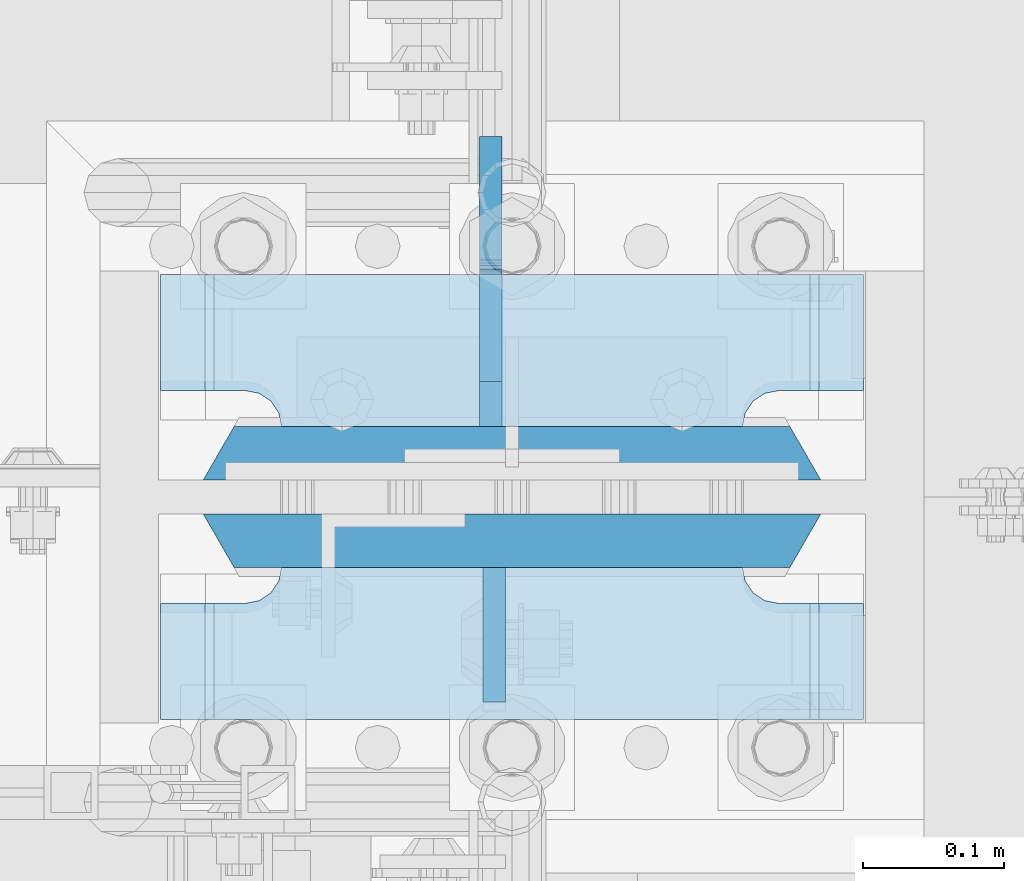
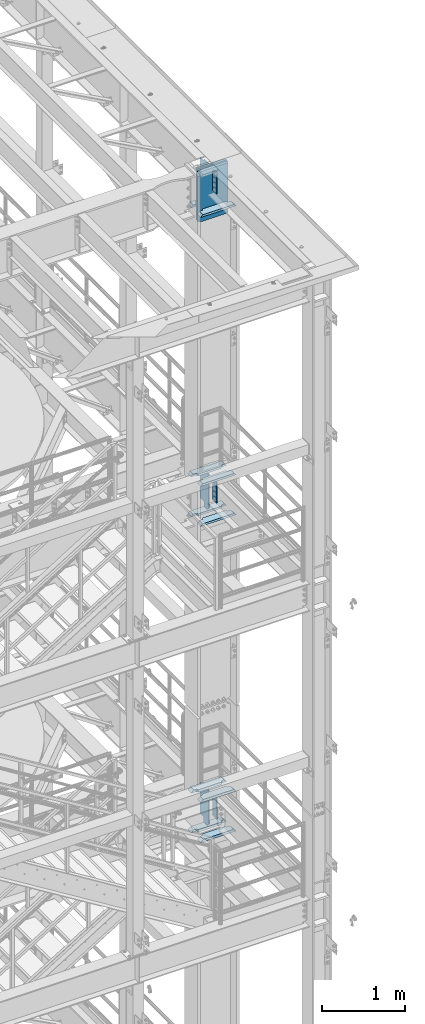
# One storey, part 1525 of 1876: 18 plates, 2 elements without a shape of their own.
"""IFC2X3 building model written with IfcOpenShell, lengths in millimetres."""

from ifc_helpers import new_model, si_unit, frame, origin_with_axes, place, context, subcontext, project, spatial, faceted_brep, material, type_object, element, aggregate, save


model = new_model("IFC2X3")

# Units and contexts
model_context = context("Model", 3, precision=1e-05, world=origin_with_axes())
body_context = subcontext(model_context, "Body", "Model", "MODEL_VIEW")
ifc_project = project(units=[si_unit("LENGTHUNIT", "METRE", prefix="MILLI"), si_unit("AREAUNIT", "SQUARE_METRE"), si_unit("VOLUMEUNIT", "CUBIC_METRE"), si_unit("MASSUNIT", "GRAM", prefix="KILO"), si_unit("TIMEUNIT", "SECOND"), si_unit("PLANEANGLEUNIT", "RADIAN"), si_unit("SOLIDANGLEUNIT", "STERADIAN"), si_unit("THERMODYNAMICTEMPERATUREUNIT", "DEGREE_CELSIUS"), si_unit("LUMINOUSINTENSITYUNIT", "LUMEN")], contexts=[model_context])

# Site, building, storey
site_placement = place(None, origin_with_axes())
site = spatial("IfcSite", under=ifc_project, at=site_placement, CompositionType="ELEMENT")
building_placement = place(site_placement, origin_with_axes())
building = spatial("IfcBuilding", under=site, at=building_placement, Name="Undefined", CompositionType="ELEMENT")
storey_placement = place(building_placement, origin_with_axes())
storey = spatial("IfcBuildingStorey", under=building, at=storey_placement, Name="Undefined", CompositionType="ELEMENT", Elevation=0.0)

# Assembly, plates
assembly_1_placement = place(storey_placement, origin_with_axes())
assembly_1 = element("IfcElementAssembly", 1, at=assembly_1_placement, inside=storey, Name="COLUMN", AssemblyPlace="NOTDEFINED", PredefinedType="RIGID_FRAME")
ifc_material_1 = material(Name="STEEL/A572-GR.50")
plate_type_1 = type_object("IfcPlateType", PredefinedType="NOTDEFINED")
plate_1_placement = place(assembly_1_placement, frame((7400.925, -4541.04375, 22523.45), z_axis=(1.0, 0.0, 0.0), x_axis=(0.0, 0.0, -1.0)))
plate_1 = element("IfcPlate", 2, at=plate_1_placement, type_object=plate_type_1, material=ifc_material_1, Name="PLATE", context=body_context, shape_type="Brep", body=[
    faceted_brep([(0.0, 19.0500000000002, 416.152954742277), (0.0, -19.0500000000002, 438.149993896484), (742.950012207031, -19.0500000000002, 438.149993896484), (742.950012207031, 19.0500000000002, 416.152954742277), (742.950012207031, 19.0500000000002, 21.9970452577325), (0.0, 19.0500000000002, 21.9970452577367), (0.0, -19.0500000000002, 0.0), (742.950012207031, -19.0500000000002, 0.0)], [[[0, 1, 2, 3]], [[0, 3, 4, 5]], [[1, 0, 5, 6]], [[2, 1, 6, 7]], [[3, 2, 7, 4]], [[6, 5, 4, 7]]]),
])
plate_2_placement = place(assembly_1_placement, frame((7400.925, -4602.95625, 22523.45), z_axis=(1.0, 0.0, 0.0), x_axis=(0.0, 0.0, -1.0)))
plate_2 = element("IfcPlate", 3, at=plate_2_placement, type_object=plate_type_1, material=ifc_material_1, Name="PLATE", context=body_context, shape_type="Brep", body=[
    faceted_brep([(0.0, -19.0500000000002, 416.152954749452), (742.950012207031, -19.0500000000002, 416.152954749372), (742.950012207031, 19.0500000000002, 438.149993896484), (0.0, 19.0500000000002, 438.149993896484), (742.950012207031, -19.0500000000002, 21.9970452506512), (742.950012207031, 19.0500000000002, 0.0), (-9.09494701772928e-13, 19.05, -1.81898940354586e-12), (0.0, -19.0500000000002, 21.9970452506512)], [[[0, 1, 2, 3]], [[2, 1, 4, 5]], [[3, 2, 5, 6]], [[0, 3, 6, 7]], [[1, 0, 7, 4]], [[6, 5, 4, 7]]]),
])
ifc_material_2 = material(Name="STEEL/A572-50")
plate_type_2 = type_object("IfcPlateType", PredefinedType="NOTDEFINED")
plate_3_placement = place(assembly_1_placement, frame((7607.30049991608, -4622.00625, 22491.7), z_axis=(0.0, -1.0, 0.0), x_axis=(0.0, 0.0, -1.0)))
plate_3 = element("IfcPlate", 4, at=plate_3_placement, type_object=plate_type_2, material=ifc_material_2, Name="PLATE", context=body_context, shape_type="Brep", body=[
    faceted_brep([(0.0, -7.9375, 0.0), (0.0, -7.9375, 95.25), (0.0, 7.9375, 95.25), (0.0, 7.9375, 0.0), (304.799987792969, -7.9375, 95.25), (304.799987792969, 7.9375, 95.25), (304.799987792969, -7.9375, 0.0), (304.799987792969, 7.9375, 0.0)], [[[0, 1, 2, 3]], [[1, 4, 5, 2]], [[4, 6, 7, 5]], [[6, 0, 3, 7]], [[5, 7, 3, 2]], [[6, 4, 1, 0]]]),
])
plate_4_placement = place(assembly_1_placement, frame((7607.30049991608, -4622.00625, 17919.7), z_axis=(0.0, -1.0, 0.0), x_axis=(0.0, 0.0, -1.0)))
plate_4 = element("IfcPlate", 5, at=plate_4_placement, type_object=plate_type_2, material=ifc_material_2, Name="PLATE", context=body_context, shape_type="Brep", body=[
    faceted_brep([(0.0, -7.9375, 0.0), (0.0, -7.9375, 95.25), (0.0, 7.9375, 95.25), (0.0, 7.9375, 0.0), (304.799987792969, -7.9375, 95.25), (304.799987792969, 7.9375, 95.25), (304.799987792969, -7.9375, 0.0), (304.799987792969, 7.9375, 0.0)], [[[0, 1, 2, 3]], [[1, 4, 5, 2]], [[4, 6, 7, 5]], [[6, 0, 3, 7]], [[5, 7, 3, 2]], [[6, 4, 1, 0]]]),
])

# Assembly, plate
assembly_2_placement = place(storey_placement, origin_with_axes())
assembly_2 = element("IfcElementAssembly", 6, at=assembly_2_placement, inside=storey, Name="COLUMN", AssemblyPlace="NOTDEFINED", PredefinedType="RIGID_FRAME")
ifc_material_3 = material(Name="STEEL/A36")
plate_5_placement = place(assembly_2_placement, frame((7607.30049991608, -4622.00625, 13246.1), z_axis=(0.0, -1.0, 0.0), x_axis=(0.0, 0.0, -1.0)))
plate_5 = element("IfcPlate", 7, at=plate_5_placement, type_object=plate_type_2, material=ifc_material_3, Name="PLATE", context=body_context, shape_type="Brep", body=[
    faceted_brep([(0.0, -7.9375, 0.0), (0.0, -7.9375, 95.25), (0.0, 7.9375, 95.25), (0.0, 7.9375, 0.0), (304.799987792969, -7.9375, 95.25), (304.799987792969, 7.9375, 95.25), (304.799987792969, -7.9375, 0.0), (304.799987792969, 7.9375, 0.0)], [[[0, 1, 2, 3]], [[1, 4, 5, 2]], [[4, 6, 7, 5]], [[6, 0, 3, 7]], [[5, 7, 3, 2]], [[6, 4, 1, 0]]]),
])

# Plate
plate_type_3 = type_object("IfcPlateType", PredefinedType="NOTDEFINED")
plate_6_placement = place(assembly_1_placement, frame((7869.2375, -4622.00625, 17376.775012207), z_axis=(-1.0, 0.0, 0.0), x_axis=(0.0, -1.0, 0.0)))
plate_6 = element("IfcPlate", 8, at=plate_6_placement, type_object=plate_type_3, material=ifc_material_2, Name="PLATE", context=body_context, shape_type="Brep", body=[
    faceted_brep([(107.949996948242, -15.875, 498.475006103516), (107.949996948242, 15.875, 467.025007631571), (25.3999996185303, 15.875, 467.025007631571), (25.3999996185303, -15.875, 498.475006103516), (23.4665397733534, -15.875, 428.429848211837), (25.3999996185303, -15.875, 438.150007247925), (25.3999996185303, 15.875, 438.150007247925), (23.4665397733534, 15.875, 428.429848211837), (17.9605119723965, -15.875, 420.189495275529), (17.9605119723965, 15.875, 420.189495275529), (9.72015903608917, -15.875, 414.683467474573), (9.72015903608917, 15.875, 414.683467474573), (0.0, -15.875, 412.750007629395), (0.0, 15.875, 412.750007629395), (0.0, -15.875, 85.7249984741211), (0.0, 15.875, 85.7249984741211), (9.72015903609099, -15.875, 83.7915386289454), (9.72015903609099, 15.875, 83.7915386289454), (17.9605119723983, -15.875, 78.2855108279892), (17.9605119723983, 15.875, 78.2855108279892), (23.4665397733552, -15.875, 70.0451578916817), (23.4665397733552, 15.875, 70.0451578916817), (25.3999996185303, -15.875, 60.3249988555908), (25.3999996185303, 15.875, 60.3249988555908), (25.3999996185303, 15.875, 31.449998471945), (25.3999996185303, -15.875, 0.0), (107.949996948242, 15.875, 31.449998471945), (107.949996948242, -15.875, 0.0)], [[[0, 1, 2, 3]], [[4, 5, 6, 7]], [[8, 4, 7, 9]], [[10, 8, 9, 11]], [[12, 10, 11, 13]], [[14, 12, 13, 15]], [[16, 14, 15, 17]], [[18, 16, 17, 19]], [[20, 18, 19, 21]], [[22, 20, 21, 23]], [[22, 23, 24, 25]], [[26, 27, 25, 24]], [[5, 4, 8, 10, 12, 14, 16, 18, 20, 22, 25, 27, 0, 3]], [[6, 5, 3, 2]], [[26, 24, 23, 21, 19, 17, 15, 13, 11, 9, 7, 6, 2, 1]], [[27, 26, 1, 0]]]),
])

plate_7_placement = place(assembly_1_placement, frame((7869.2375, -4622.00625, 17967.325), z_axis=(-1.0, 0.0, 0.0), x_axis=(0.0, -1.0, 0.0)))
plate_7 = element("IfcPlate", 9, at=plate_7_placement, type_object=plate_type_3, material=ifc_material_2, Name="PLATE", context=body_context, shape_type="Brep", body=[
    faceted_brep([(107.949996948242, -15.875, 498.475006103516), (107.949996948242, 15.875, 467.025007631571), (25.3999996185303, 15.875, 467.025007631571), (25.3999996185303, -15.875, 498.475006103516), (23.4665397733534, -15.875, 428.429848211837), (25.3999996185303, -15.875, 438.150007247925), (25.3999996185303, 15.875, 438.150007247925), (23.4665397733534, 15.875, 428.429848211837), (17.9605119723965, -15.875, 420.189495275529), (17.9605119723965, 15.875, 420.189495275529), (9.72015903608917, -15.875, 414.683467474573), (9.72015903608917, 15.875, 414.683467474573), (0.0, -15.875, 412.750007629395), (0.0, 15.875, 412.750007629395), (0.0, -15.875, 85.7249984741211), (0.0, 15.875, 85.7249984741211), (9.72015903609099, -15.875, 83.7915386289454), (9.72015903609099, 15.875, 83.7915386289454), (17.9605119723983, -15.875, 78.2855108279892), (17.9605119723983, 15.875, 78.2855108279892), (23.4665397733552, -15.875, 70.0451578916817), (23.4665397733552, 15.875, 70.0451578916817), (25.3999996185303, -15.875, 60.3249988555908), (25.3999996185303, 15.875, 60.3249988555908), (25.3999996185303, 15.875, 31.449998471945), (25.3999996185303, -15.875, 0.0), (107.949996948242, 15.875, 31.449998471945), (107.949996948242, -15.875, 0.0)], [[[0, 1, 2, 3]], [[4, 5, 6, 7]], [[8, 4, 7, 9]], [[10, 8, 9, 11]], [[12, 10, 11, 13]], [[14, 12, 13, 15]], [[16, 14, 15, 17]], [[18, 16, 17, 19]], [[20, 18, 19, 21]], [[22, 20, 21, 23]], [[22, 23, 24, 25]], [[26, 27, 25, 24]], [[5, 4, 8, 10, 12, 14, 16, 18, 20, 22, 25, 27, 0, 3]], [[6, 5, 3, 2]], [[26, 24, 23, 21, 19, 17, 15, 13, 11, 9, 7, 6, 2, 1]], [[27, 26, 1, 0]]]),
])

plate_8_placement = place(assembly_1_placement, frame((7869.2375, -4414.04375, 17376.775012207), z_axis=(-1.0, 0.0, 0.0), x_axis=(0.0, -1.0, 0.0)))
plate_8 = element("IfcPlate", 10, at=plate_8_placement, type_object=plate_type_3, material=ifc_material_2, Name="PLATE", context=body_context, shape_type="Brep", body=[
    faceted_brep([(82.5499973297119, -15.875, 498.475006103516), (82.5499973297119, 15.875, 467.025007631571), (0.0, 15.875, 467.025007631571), (0.0, -15.875, 498.475006103516), (82.5499973297119, 15.875, 31.449998471945), (82.5499973297119, -15.875, 0.0), (0.0, -15.875, 0.0), (0.0, 15.875, 31.449998471945), (82.5499973297119, 15.875, 60.3249988555908), (82.5499973297119, -15.875, 60.3249988555908), (84.4834571748879, -15.875, 70.045157891682), (84.4834571748879, 15.875, 70.045157891682), (89.9894849758439, -15.875, 78.2855108279893), (89.9894849758439, 15.875, 78.2855108279893), (98.2298379121512, -15.875, 83.7915386289454), (98.2298379121512, 15.875, 83.7915386289454), (107.949996948242, -15.875, 85.7249984741211), (107.949996948242, 15.875, 85.7249984741211), (107.949996948242, -15.875, 412.750007629395), (107.949996948242, 15.875, 412.750007629395), (98.2298379121512, -15.875, 414.68346747457), (98.2298379121512, 15.875, 414.68346747457), (89.989484975843, -15.875, 420.189495275526), (89.989484975843, 15.875, 420.189495275526), (84.483457174887, -15.875, 428.429848211834), (84.483457174887, 15.875, 428.429848211834), (82.5499973297119, -15.875, 438.150007247925), (82.5499973297119, 15.875, 438.150007247925)], [[[0, 1, 2, 3]], [[4, 5, 6, 7]], [[8, 9, 5, 4]], [[10, 9, 8, 11]], [[12, 10, 11, 13]], [[14, 12, 13, 15]], [[16, 14, 15, 17]], [[18, 16, 17, 19]], [[20, 18, 19, 21]], [[22, 20, 21, 23]], [[24, 22, 23, 25]], [[26, 24, 25, 27]], [[6, 5, 9, 10, 12, 14, 16, 18, 20, 22, 24, 26, 0, 3]], [[7, 6, 3, 2]], [[27, 25, 23, 21, 19, 17, 15, 13, 11, 8, 4, 7, 2, 1]], [[26, 27, 1, 0]]]),
])

plate_9_placement = place(assembly_1_placement, frame((7869.2375, -4414.04375, 17967.325), z_axis=(-1.0, 0.0, 0.0), x_axis=(0.0, -1.0, 0.0)))
plate_9 = element("IfcPlate", 11, at=plate_9_placement, type_object=plate_type_3, material=ifc_material_2, Name="PLATE", context=body_context, shape_type="Brep", body=[
    faceted_brep([(82.5499973297119, -15.875, 498.475006103516), (82.5499973297119, 15.875, 467.025007631571), (0.0, 15.875, 467.025007631571), (0.0, -15.875, 498.475006103516), (82.5499973297119, 15.875, 31.449998471945), (82.5499973297119, -15.875, 0.0), (0.0, -15.875, 0.0), (0.0, 15.875, 31.449998471945), (82.5499973297119, 15.875, 60.3249988555908), (82.5499973297119, -15.875, 60.3249988555908), (84.4834571748879, -15.875, 70.045157891682), (84.4834571748879, 15.875, 70.045157891682), (89.9894849758439, -15.875, 78.2855108279893), (89.9894849758439, 15.875, 78.2855108279893), (98.2298379121512, -15.875, 83.7915386289454), (98.2298379121512, 15.875, 83.7915386289454), (107.949996948242, -15.875, 85.7249984741211), (107.949996948242, 15.875, 85.7249984741211), (107.949996948242, -15.875, 412.750007629395), (107.949996948242, 15.875, 412.750007629395), (98.2298379121512, -15.875, 414.68346747457), (98.2298379121512, 15.875, 414.68346747457), (89.989484975843, -15.875, 420.189495275526), (89.989484975843, 15.875, 420.189495275526), (84.483457174887, -15.875, 428.429848211834), (84.483457174887, 15.875, 428.429848211834), (82.5499973297119, -15.875, 438.150007247925), (82.5499973297119, 15.875, 438.150007247925)], [[[0, 1, 2, 3]], [[4, 5, 6, 7]], [[8, 9, 5, 4]], [[10, 9, 8, 11]], [[12, 10, 11, 13]], [[14, 12, 13, 15]], [[16, 14, 15, 17]], [[18, 16, 17, 19]], [[20, 18, 19, 21]], [[22, 20, 21, 23]], [[24, 22, 23, 25]], [[26, 24, 25, 27]], [[6, 5, 9, 10, 12, 14, 16, 18, 20, 22, 24, 26, 0, 3]], [[7, 6, 3, 2]], [[27, 25, 23, 21, 19, 17, 15, 13, 11, 8, 4, 7, 2, 1]], [[26, 27, 1, 0]]]),
])

plate_10_placement = place(assembly_1_placement, frame((7869.2375, -4622.00625, 21948.775012207), z_axis=(-1.0, 0.0, 0.0), x_axis=(0.0, -1.0, 0.0)))
plate_10 = element("IfcPlate", 12, at=plate_10_placement, type_object=plate_type_3, material=ifc_material_2, Name="PLATE", context=body_context, shape_type="Brep", body=[
    faceted_brep([(107.949996948242, -15.875, 498.475006103516), (107.949996948242, 15.875, 467.025007631571), (25.3999996185303, 15.875, 467.025007631571), (25.3999996185303, -15.875, 498.475006103516), (23.4665397733534, -15.875, 428.429848211837), (25.3999996185303, -15.875, 438.150007247925), (25.3999996185303, 15.875, 438.150007247925), (23.4665397733534, 15.875, 428.429848211837), (17.9605119723965, -15.875, 420.189495275529), (17.9605119723965, 15.875, 420.189495275529), (9.72015903608917, -15.875, 414.683467474573), (9.72015903608917, 15.875, 414.683467474573), (0.0, -15.875, 412.750007629395), (0.0, 15.875, 412.750007629395), (0.0, -15.875, 85.7249984741211), (0.0, 15.875, 85.7249984741211), (9.72015903609099, -15.875, 83.7915386289454), (9.72015903609099, 15.875, 83.7915386289454), (17.9605119723983, -15.875, 78.2855108279892), (17.9605119723983, 15.875, 78.2855108279892), (23.4665397733552, -15.875, 70.0451578916817), (23.4665397733552, 15.875, 70.0451578916817), (25.3999996185303, -15.875, 60.3249988555908), (25.3999996185303, 15.875, 60.3249988555908), (25.3999996185303, 15.875, 31.449998471945), (25.3999996185303, -15.875, 0.0), (107.949996948242, 15.875, 31.449998471945), (107.949996948242, -15.875, 0.0)], [[[0, 1, 2, 3]], [[4, 5, 6, 7]], [[8, 4, 7, 9]], [[10, 8, 9, 11]], [[12, 10, 11, 13]], [[14, 12, 13, 15]], [[16, 14, 15, 17]], [[18, 16, 17, 19]], [[20, 18, 19, 21]], [[22, 20, 21, 23]], [[22, 23, 24, 25]], [[26, 27, 25, 24]], [[5, 4, 8, 10, 12, 14, 16, 18, 20, 22, 25, 27, 0, 3]], [[6, 5, 3, 2]], [[26, 24, 23, 21, 19, 17, 15, 13, 11, 9, 7, 6, 2, 1]], [[27, 26, 1, 0]]]),
])

plate_11_placement = place(assembly_1_placement, frame((7869.2375, -4414.04375, 21948.775012207), z_axis=(-1.0, 0.0, 0.0), x_axis=(0.0, -1.0, 0.0)))
plate_11 = element("IfcPlate", 13, at=plate_11_placement, type_object=plate_type_3, material=ifc_material_2, Name="PLATE", context=body_context, shape_type="Brep", body=[
    faceted_brep([(82.5499973297119, -15.875, 498.475006103516), (82.5499973297119, 15.875, 467.025007631571), (0.0, 15.875, 467.025007631571), (0.0, -15.875, 498.475006103516), (82.5499973297119, 15.875, 31.449998471945), (82.5499973297119, -15.875, 0.0), (0.0, -15.875, 0.0), (0.0, 15.875, 31.449998471945), (82.5499973297119, 15.875, 60.3249988555908), (82.5499973297119, -15.875, 60.3249988555908), (84.4834571748879, -15.875, 70.045157891682), (84.4834571748879, 15.875, 70.045157891682), (89.9894849758439, -15.875, 78.2855108279893), (89.9894849758439, 15.875, 78.2855108279893), (98.2298379121512, -15.875, 83.7915386289454), (98.2298379121512, 15.875, 83.7915386289454), (107.949996948242, -15.875, 85.7249984741211), (107.949996948242, 15.875, 85.7249984741211), (107.949996948242, -15.875, 412.750007629395), (107.949996948242, 15.875, 412.750007629395), (98.2298379121512, -15.875, 414.68346747457), (98.2298379121512, 15.875, 414.68346747457), (89.989484975843, -15.875, 420.189495275526), (89.989484975843, 15.875, 420.189495275526), (84.483457174887, -15.875, 428.429848211834), (84.483457174887, 15.875, 428.429848211834), (82.5499973297119, -15.875, 438.150007247925), (82.5499973297119, 15.875, 438.150007247925)], [[[0, 1, 2, 3]], [[4, 5, 6, 7]], [[8, 9, 5, 4]], [[10, 9, 8, 11]], [[12, 10, 11, 13]], [[14, 12, 13, 15]], [[16, 14, 15, 17]], [[18, 16, 17, 19]], [[20, 18, 19, 21]], [[22, 20, 21, 23]], [[24, 22, 23, 25]], [[26, 24, 25, 27]], [[6, 5, 9, 10, 12, 14, 16, 18, 20, 22, 24, 26, 0, 3]], [[7, 6, 3, 2]], [[27, 25, 23, 21, 19, 17, 15, 13, 11, 8, 4, 7, 2, 1]], [[26, 27, 1, 0]]]),
])

plate_type_4 = type_object("IfcPlateType", PredefinedType="NOTDEFINED")
plate_12_placement = place(assembly_1_placement, frame((7604.91875, -4521.99375, 17951.45), z_axis=(0.0, 1.0, 0.0), x_axis=(0.0, 0.0, -1.0)))
plate_12 = element("IfcPlate", 14, at=plate_12_placement, type_object=plate_type_4, material=ifc_material_3, Name="PLATE", context=body_context, shape_type="Brep", body=[
    faceted_brep([(488.949999999997, -7.93749999999998, 205.581253456207), (488.949999999997, -7.93749999999998, 120.649999809266), (488.949999999997, 7.93749999999999, 120.649999809266), (488.949999999997, 7.93749999999999, 205.581253051758), (489.916729922585, -7.93749999999998, 115.78992029122), (489.916729922585, 7.93749999999999, 115.78992029122), (492.669743823062, -7.93749999999998, 111.669743823067), (492.669743823062, 7.93749999999999, 111.669743823067), (496.789920291216, -7.93749999999998, 108.916729922588), (496.789920291216, 7.93749999999999, 108.916729922588), (501.649999809262, -7.93749999999998, 107.950000000001), (501.649999809262, 7.93749999999999, 107.950000000001), (558.799987792969, -7.93749999999998, 107.950000000001), (558.799987792969, 7.93749999999999, 107.950000000001), (31.7499984741225, -7.93749999999998, 205.581256103516), (31.7499984741225, 7.93749999999999, 205.581253051758), (31.7499984741225, 7.93749999999999, 120.649999809266), (31.7499984741225, -7.93749999999998, 120.649999809266), (30.783268551535, 7.93749999999999, 115.78992029122), (30.783268551535, -7.93749999999998, 115.78992029122), (28.0302546510575, 7.93749999999999, 111.669743823067), (28.0302546510575, -7.93749999999998, 111.669743823067), (23.9100781829038, 7.93749999999999, 108.916729922588), (23.9100781829038, -7.93749999999998, 108.916729922588), (19.0499986648574, 7.93749999999999, 107.950000000001), (19.0499986648574, -7.93749999999998, 107.950000000001), (0.0, 7.93749999999999, 107.950000000001), (0.0, -7.93749999999998, 107.950000000001), (0.0, 7.93749999999999, 31.75), (0.0, -7.93749999999998, 31.75), (31.75, -7.93749999999998, 0.0), (31.75, 7.93749999999999, 0.0), (527.049987792969, -7.93749999999998, 0.0), (527.049987792969, 7.93749999999999, 0.0), (558.799987792969, -7.93749999999998, 31.75), (558.799987792969, 7.93749999999999, 31.75)], [[[0, 1, 2, 3]], [[4, 5, 2, 1]], [[6, 7, 5, 4]], [[8, 9, 7, 6]], [[10, 11, 9, 8]], [[12, 13, 11, 10]], [[14, 15, 16, 17]], [[17, 16, 18, 19]], [[19, 18, 20, 21]], [[21, 20, 22, 23]], [[23, 22, 24, 25]], [[25, 24, 26, 27]], [[28, 29, 27, 26]], [[30, 29, 28, 31]], [[32, 30, 31, 33]], [[34, 32, 33, 35]], [[8, 6, 4, 1, 0, 14, 17, 19, 21, 23, 25, 27, 29, 30, 32, 34, 12, 10]], [[15, 14, 0, 3]], [[35, 33, 31, 28, 26, 24, 22, 20, 18, 16, 15, 3, 2, 5, 7, 9, 11, 13]], [[34, 35, 13, 12]]]),
])

plate_13_placement = place(assembly_1_placement, frame((7604.91949987411, -4521.99375, 22523.45), z_axis=(0.0, 1.0, 0.0), x_axis=(0.0, 0.0, -1.0)))
plate_13 = element("IfcPlate", 15, at=plate_13_placement, type_object=plate_type_4, material=ifc_material_3, Name="PLATE", context=body_context, shape_type="Brep", body=[
    faceted_brep([(488.949999999997, -7.93749999999998, 205.581253456207), (488.949999999997, -7.93749999999998, 120.649999809266), (488.949999999997, 7.93749999999999, 120.649999809266), (488.949999999997, 7.93749999999999, 205.581253051758), (489.916729922585, -7.93749999999998, 115.78992029122), (489.916729922585, 7.93749999999999, 115.78992029122), (492.669743823062, -7.93749999999998, 111.669743823067), (492.669743823062, 7.93749999999999, 111.669743823067), (496.789920291216, -7.93749999999998, 108.916729922588), (496.789920291216, 7.93749999999999, 108.916729922588), (501.649999809262, -7.93749999999998, 107.950000000001), (501.649999809262, 7.93749999999999, 107.950000000001), (558.799987792969, -7.93749999999998, 107.950000000001), (558.799987792969, 7.93749999999999, 107.950000000001), (31.7499984741225, -7.93749999999998, 205.581256103516), (31.7499984741225, 7.93749999999999, 205.581253051758), (31.7499984741225, 7.93749999999999, 120.649999809266), (31.7499984741225, -7.93749999999998, 120.649999809266), (30.783268551535, 7.93749999999999, 115.78992029122), (30.783268551535, -7.93749999999998, 115.78992029122), (28.0302546510575, 7.93749999999999, 111.669743823067), (28.0302546510575, -7.93749999999998, 111.669743823067), (23.9100781829038, 7.93749999999999, 108.916729922588), (23.9100781829038, -7.93749999999998, 108.916729922588), (19.0499986648574, 7.93749999999999, 107.950000000001), (19.0499986648574, -7.93749999999998, 107.950000000001), (0.0, 7.93749999999999, 107.950000000001), (0.0, -7.93749999999998, 107.950000000001), (0.0, 7.93749999999999, 31.75), (0.0, -7.93749999999998, 31.75), (31.75, -7.93749999999998, 0.0), (31.75, 7.93749999999999, 0.0), (527.049987792969, -7.93749999999998, 0.0), (527.049987792969, 7.93749999999999, 0.0), (558.799987792969, -7.93749999999998, 31.75), (558.799987792969, 7.93749999999999, 31.75)], [[[0, 1, 2, 3]], [[4, 5, 2, 1]], [[6, 7, 5, 4]], [[8, 9, 7, 6]], [[10, 11, 9, 8]], [[12, 13, 11, 10]], [[14, 15, 16, 17]], [[17, 16, 18, 19]], [[19, 18, 20, 21]], [[21, 20, 22, 23]], [[23, 22, 24, 25]], [[25, 24, 26, 27]], [[28, 29, 27, 26]], [[30, 29, 28, 31]], [[32, 30, 31, 33]], [[34, 32, 33, 35]], [[8, 6, 4, 1, 0, 14, 17, 19, 21, 23, 25, 27, 29, 30, 32, 34, 12, 10]], [[15, 14, 0, 3]], [[35, 33, 31, 28, 26, 24, 22, 20, 18, 16, 15, 3, 2, 5, 7, 9, 11, 13]], [[34, 35, 13, 12]]]),
])

aggregate(assembly_1, [plate_3, plate_4, plate_6, plate_7, plate_8, plate_9, plate_12, plate_10, plate_11, plate_13, plate_1, plate_2])

plate_14_placement = place(assembly_2_placement, frame((7604.91949987411, -4521.99375, 13271.5), z_axis=(0.0, 1.0, 0.0), x_axis=(0.0, 0.0, -1.0)))
plate_14 = element("IfcPlate", 16, at=plate_14_placement, type_object=plate_type_4, material=ifc_material_3, Name="PLATE", context=body_context, shape_type="Brep", body=[
    faceted_brep([(482.600012207031, -7.9375, 205.581252647308), (482.600012207031, -7.9375, 123.031246757508), (482.600012207031, 7.9375, 123.031246757508), (482.600012207031, 7.9375, 205.581253051758), (483.566742129618, -7.9375, 118.171167239462), (483.566742129618, 7.9375, 118.171167239462), (486.319756030096, -7.9375, 114.050990771309), (486.319756030096, 7.9375, 114.050990771309), (490.43993249825, -7.9375, 111.29797687083), (490.43993249825, 7.9375, 111.29797687083), (495.300012016296, -7.9375, 110.331246948243), (495.300012016296, 7.9375, 110.331246948243), (552.450012207031, -7.9375, 110.331246948243), (552.450012207031, 7.9375, 110.331246948243), (25.3999996185303, -7.9375, 205.581249999999), (25.3999996185303, 7.9375, 205.581253051758), (25.3999996185303, 7.9375, 123.031249809264), (25.3999996185303, -7.9375, 123.031249809264), (24.4332696959427, 7.9375, 118.171170291219), (24.4332696959427, -7.9375, 118.171170291219), (21.6802557954652, 7.9375, 114.050993823065), (21.6802557954652, -7.9375, 114.050993823065), (17.5600793273115, 7.9375, 111.297979922587), (17.5600793273115, -7.9375, 111.297979922587), (12.6999998092651, 7.9375, 110.331249999999), (12.6999998092651, -7.9375, 110.331249999999), (0.0, 7.9375, 110.33125), (0.0, -7.9375, 110.33125), (0.0, 7.93749999999999, 31.75), (0.0, -7.93749999999998, 31.75), (31.75, -7.93749999999998, 0.0), (31.75, 7.93749999999999, 0.0), (520.700012207031, -7.9375, 0.0), (520.700012207031, 7.9375, 0.0), (552.450012207031, -7.9375, 31.75), (552.450012207031, 7.9375, 31.75)], [[[0, 1, 2, 3]], [[4, 5, 2, 1]], [[6, 7, 5, 4]], [[8, 9, 7, 6]], [[10, 11, 9, 8]], [[12, 13, 11, 10]], [[14, 15, 16, 17]], [[17, 16, 18, 19]], [[19, 18, 20, 21]], [[21, 20, 22, 23]], [[23, 22, 24, 25]], [[25, 24, 26, 27]], [[28, 29, 27, 26]], [[30, 29, 28, 31]], [[32, 30, 31, 33]], [[34, 32, 33, 35]], [[8, 6, 4, 1, 0, 14, 17, 19, 21, 23, 25, 27, 29, 30, 32, 34, 12, 10]], [[15, 14, 0, 3]], [[35, 33, 31, 28, 26, 24, 22, 20, 18, 16, 15, 3, 2, 5, 7, 9, 11, 13]], [[34, 35, 13, 12]]]),
])

plate_type_5 = type_object("IfcPlateType", PredefinedType="NOTDEFINED")
plate_15_placement = place(assembly_2_placement, frame((7869.2375, -4622.00625, 12699.999987793), z_axis=(-1.0, 0.0, 0.0), x_axis=(0.0, -1.0, 0.0)))
plate_15 = element("IfcPlate", 17, at=plate_15_placement, type_object=plate_type_5, material=ifc_material_2, Name="PLATE", context=body_context, shape_type="Brep", body=[
    faceted_brep([(107.949996948242, -19.0499999999993, 498.475006103516), (107.949996948242, 19.0499999999993, 460.675005342751), (25.3999996185303, 19.0499999999993, 460.675005342751), (25.3999996185303, -19.0499999999993, 498.475006103516), (23.4665397733534, -19.0499999999993, 428.429848211837), (25.3999996185303, -19.0499999999993, 438.150007247925), (25.3999996185303, 19.0499999999993, 438.150007247925), (23.4665397733534, 19.0499999999993, 428.429848211837), (17.9605119723965, -19.0499999999993, 420.189495275529), (17.9605119723965, 19.0499999999993, 420.189495275529), (9.72015903608917, -19.0499999999993, 414.683467474573), (9.72015903608917, 19.0499999999993, 414.683467474573), (0.0, -19.0499999999993, 412.750007629395), (0.0, 19.0499999999993, 412.750007629395), (0.0, -19.0499999999993, 85.7249984741211), (0.0, 19.0499999999993, 85.7249984741211), (9.72015903609099, -19.0499999999993, 83.7915386289451), (9.72015903609099, 19.0499999999993, 83.7915386289451), (17.9605119723983, -19.0499999999993, 78.2855108279891), (17.9605119723983, 19.0499999999993, 78.2855108279891), (23.4665397733552, -19.0499999999993, 70.0451578916818), (23.4665397733552, 19.0499999999993, 70.0451578916818), (25.3999996185303, -19.0499999999993, 60.3249988555908), (25.3999996185303, 19.0499999999993, 60.3249988555908), (25.3999996185303, 19.0499999999993, 37.8000007607643), (25.3999996185303, -19.0499999999993, 0.0), (107.949996948242, 19.0499999999993, 37.8000007607643), (107.949996948242, -19.0499999999993, 0.0)], [[[0, 1, 2, 3]], [[4, 5, 6, 7]], [[8, 4, 7, 9]], [[10, 8, 9, 11]], [[12, 10, 11, 13]], [[14, 12, 13, 15]], [[16, 14, 15, 17]], [[18, 16, 17, 19]], [[20, 18, 19, 21]], [[22, 20, 21, 23]], [[22, 23, 24, 25]], [[26, 27, 25, 24]], [[5, 4, 8, 10, 12, 14, 16, 18, 20, 22, 25, 27, 0, 3]], [[6, 5, 3, 2]], [[26, 24, 23, 21, 19, 17, 15, 13, 11, 9, 7, 6, 2, 1]], [[27, 26, 1, 0]]]),
])

plate_16_placement = place(assembly_2_placement, frame((7869.2375, -4622.00625, 13290.55), z_axis=(-1.0, 0.0, 0.0), x_axis=(0.0, -1.0, 0.0)))
plate_16 = element("IfcPlate", 18, at=plate_16_placement, type_object=plate_type_5, material=ifc_material_2, Name="PLATE", context=body_context, shape_type="Brep", body=[
    faceted_brep([(107.949996948242, -19.0499999999993, 498.475006103516), (107.949996948242, 19.0499999999993, 460.675005342751), (25.3999996185303, 19.0499999999993, 460.675005342751), (25.3999996185303, -19.0499999999993, 498.475006103516), (23.4665397733534, -19.0499999999993, 428.429848211837), (25.3999996185303, -19.0499999999993, 438.150007247925), (25.3999996185303, 19.0499999999993, 438.150007247925), (23.4665397733534, 19.0499999999993, 428.429848211837), (17.9605119723965, -19.0499999999993, 420.189495275529), (17.9605119723965, 19.0499999999993, 420.189495275529), (9.72015903608917, -19.0499999999993, 414.683467474573), (9.72015903608917, 19.0499999999993, 414.683467474573), (0.0, -19.0499999999993, 412.750007629395), (0.0, 19.0499999999993, 412.750007629395), (0.0, -19.0499999999993, 85.7249984741211), (0.0, 19.0499999999993, 85.7249984741211), (9.72015903609099, -19.0499999999993, 83.7915386289451), (9.72015903609099, 19.0499999999993, 83.7915386289451), (17.9605119723983, -19.0499999999993, 78.2855108279891), (17.9605119723983, 19.0499999999993, 78.2855108279891), (23.4665397733552, -19.0499999999993, 70.0451578916818), (23.4665397733552, 19.0499999999993, 70.0451578916818), (25.3999996185303, -19.0499999999993, 60.3249988555908), (25.3999996185303, 19.0499999999993, 60.3249988555908), (25.3999996185303, 19.0499999999993, 37.8000007607643), (25.3999996185303, -19.0499999999993, 0.0), (107.949996948242, 19.0499999999993, 37.8000007607643), (107.949996948242, -19.0499999999993, 0.0)], [[[0, 1, 2, 3]], [[4, 5, 6, 7]], [[8, 4, 7, 9]], [[10, 8, 9, 11]], [[12, 10, 11, 13]], [[14, 12, 13, 15]], [[16, 14, 15, 17]], [[18, 16, 17, 19]], [[20, 18, 19, 21]], [[22, 20, 21, 23]], [[22, 23, 24, 25]], [[26, 27, 25, 24]], [[5, 4, 8, 10, 12, 14, 16, 18, 20, 22, 25, 27, 0, 3]], [[6, 5, 3, 2]], [[26, 24, 23, 21, 19, 17, 15, 13, 11, 9, 7, 6, 2, 1]], [[27, 26, 1, 0]]]),
])

plate_17_placement = place(assembly_2_placement, frame((7869.2375, -4414.04375, 12699.999987793), z_axis=(-1.0, 0.0, 0.0), x_axis=(0.0, -1.0, 0.0)))
plate_17 = element("IfcPlate", 19, at=plate_17_placement, type_object=plate_type_5, material=ifc_material_2, Name="PLATE", context=body_context, shape_type="Brep", body=[
    faceted_brep([(82.5499973297119, -19.0499999999993, 498.475006103516), (82.5499973297119, 19.0499999999993, 460.675005342751), (0.0, 19.0499999999993, 460.675005342751), (0.0, -19.0499999999993, 498.475006103516), (82.5499973297119, 19.0499999999993, 37.8000007607643), (82.5499973297119, -19.0499999999993, 0.0), (0.0, -19.0500000000002, 0.0), (0.0, 19.0499999999993, 37.8000007607643), (82.5499973297119, 19.0499999999993, 60.3249988555908), (82.5499973297119, -19.0499999999993, 60.3249988555908), (84.4834571748879, -19.0499999999993, 70.0451578916818), (84.4834571748879, 19.0499999999993, 70.0451578916818), (89.9894849758439, -19.0499999999993, 78.2855108279891), (89.9894849758439, 19.0499999999993, 78.2855108279891), (98.2298379121512, -19.0499999999993, 83.7915386289451), (98.2298379121512, 19.0499999999993, 83.7915386289451), (107.949996948242, -19.0499999999993, 85.7249984741211), (107.949996948242, 19.0499999999993, 85.7249984741211), (107.949996948242, -19.0499999999993, 412.750007629395), (107.949996948242, 19.0499999999993, 412.750007629395), (98.2298379121512, -19.0499999999993, 414.683467474571), (98.2298379121512, 19.0499999999993, 414.683467474571), (89.989484975843, -19.0499999999993, 420.189495275526), (89.989484975843, 19.0499999999993, 420.189495275526), (84.483457174887, -19.0499999999993, 428.429848211834), (84.483457174887, 19.0499999999993, 428.429848211834), (82.5499973297119, -19.0499999999993, 438.150007247925), (82.5499973297119, 19.0499999999993, 438.150007247925)], [[[0, 1, 2, 3]], [[4, 5, 6, 7]], [[8, 9, 5, 4]], [[10, 9, 8, 11]], [[12, 10, 11, 13]], [[14, 12, 13, 15]], [[16, 14, 15, 17]], [[18, 16, 17, 19]], [[20, 18, 19, 21]], [[22, 20, 21, 23]], [[24, 22, 23, 25]], [[26, 24, 25, 27]], [[6, 5, 9, 10, 12, 14, 16, 18, 20, 22, 24, 26, 0, 3]], [[7, 6, 3, 2]], [[27, 25, 23, 21, 19, 17, 15, 13, 11, 8, 4, 7, 2, 1]], [[26, 27, 1, 0]]]),
])

plate_18_placement = place(assembly_2_placement, frame((7869.2375, -4414.04375, 13290.55), z_axis=(-1.0, 0.0, 0.0), x_axis=(0.0, -1.0, 0.0)))
plate_18 = element("IfcPlate", 20, at=plate_18_placement, type_object=plate_type_5, material=ifc_material_2, Name="PLATE", context=body_context, shape_type="Brep", body=[
    faceted_brep([(82.5499973297119, -19.0499999999993, 498.475006103516), (82.5499973297119, 19.0499999999993, 460.675005342751), (0.0, 19.0499999999993, 460.675005342751), (0.0, -19.0499999999993, 498.475006103516), (82.5499973297119, 19.0499999999993, 37.8000007607643), (82.5499973297119, -19.0499999999993, 0.0), (0.0, -19.0500000000002, 0.0), (0.0, 19.0499999999993, 37.8000007607643), (82.5499973297119, 19.0499999999993, 60.3249988555908), (82.5499973297119, -19.0499999999993, 60.3249988555908), (84.4834571748879, -19.0499999999993, 70.0451578916818), (84.4834571748879, 19.0499999999993, 70.0451578916818), (89.9894849758439, -19.0499999999993, 78.2855108279891), (89.9894849758439, 19.0499999999993, 78.2855108279891), (98.2298379121512, -19.0499999999993, 83.7915386289451), (98.2298379121512, 19.0499999999993, 83.7915386289451), (107.949996948242, -19.0499999999993, 85.7249984741211), (107.949996948242, 19.0499999999993, 85.7249984741211), (107.949996948242, -19.0499999999993, 412.750007629395), (107.949996948242, 19.0499999999993, 412.750007629395), (98.2298379121512, -19.0499999999993, 414.683467474571), (98.2298379121512, 19.0499999999993, 414.683467474571), (89.989484975843, -19.0499999999993, 420.189495275526), (89.989484975843, 19.0499999999993, 420.189495275526), (84.483457174887, -19.0499999999993, 428.429848211834), (84.483457174887, 19.0499999999993, 428.429848211834), (82.5499973297119, -19.0499999999993, 438.150007247925), (82.5499973297119, 19.0499999999993, 438.150007247925)], [[[0, 1, 2, 3]], [[4, 5, 6, 7]], [[8, 9, 5, 4]], [[10, 9, 8, 11]], [[12, 10, 11, 13]], [[14, 12, 13, 15]], [[16, 14, 15, 17]], [[18, 16, 17, 19]], [[20, 18, 19, 21]], [[22, 20, 21, 23]], [[24, 22, 23, 25]], [[26, 24, 25, 27]], [[6, 5, 9, 10, 12, 14, 16, 18, 20, 22, 24, 26, 0, 3]], [[7, 6, 3, 2]], [[27, 25, 23, 21, 19, 17, 15, 13, 11, 8, 4, 7, 2, 1]], [[26, 27, 1, 0]]]),
])

aggregate(assembly_2, [plate_5, plate_15, plate_16, plate_17, plate_18, plate_14])

save(model, "model.ifc")
